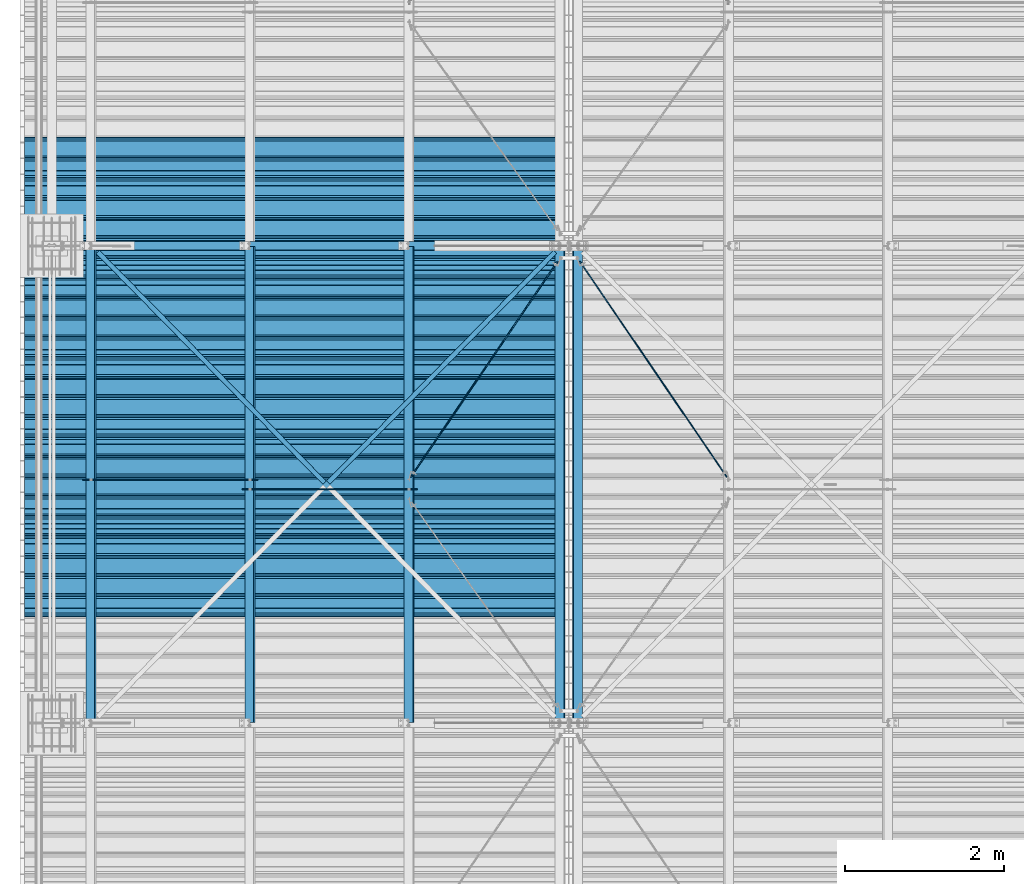
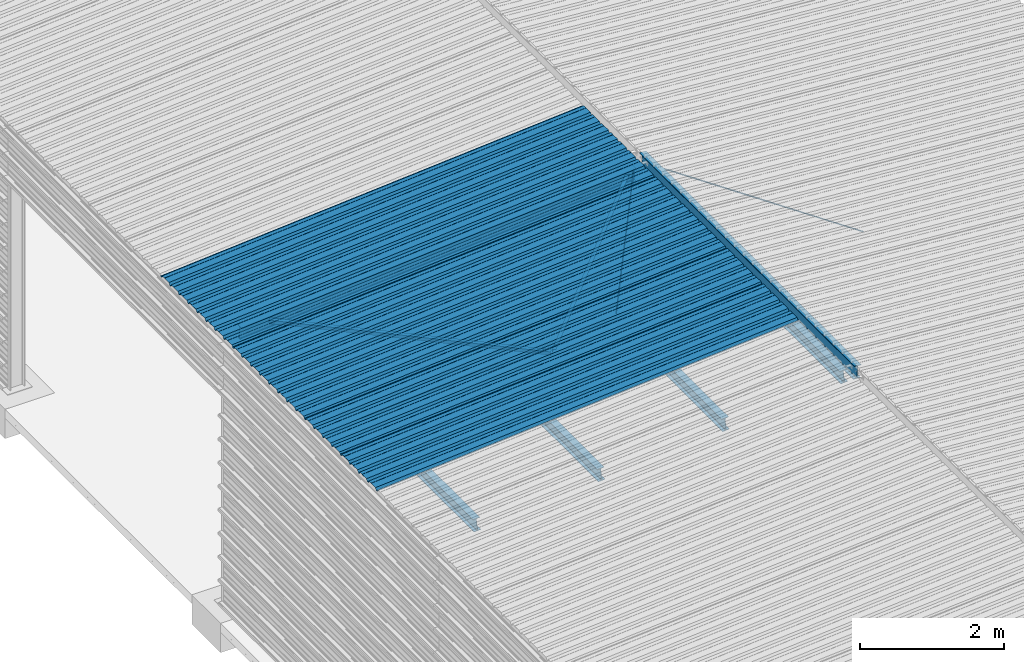
# One storey, part 11 of 70: 18 beams, 18 elements without a shape of their own.
"""IFC2X3 building model written with IfcOpenShell, lengths in millimetres."""

import ifcopenshell
import ifcopenshell.guid

model = None  # the IFC model being written
_history = None  # IfcOwnerHistory: only IFC2X3 demands one
_inside = {}  # id of a spatial element -> (the spatial element, [elements in it])
_under = {}  # id of a project, library or spatial element -> (it, [spatial elements below it])
_declared = {}  # id of a project -> (the project, [libraries it declares])
_typed = {}  # id of a type object -> (the type object, [elements of that type])
_made_of = {}  # id of a material, layer set ... -> (it, [elements and type objects made of it])


def new_model(schema):
    """Start an empty IFC model of exactly this schema.

    Asked for "IFC4X3", IfcOpenShell would pick the latest addendum, in which some entities
    have other attributes; the version numbers below select the first issue.
    IFC2X3 requires an IfcOwnerHistory on every rooted entity: one is made here for all.
    """
    global model, _history
    if schema == "IFC4X3":
        model = ifcopenshell.file(schema_version=(4, 3, 0, 0))
    else:
        model = ifcopenshell.file(schema=schema)
    _inside.clear()
    _under.clear()
    _declared.clear()
    _typed.clear()
    _made_of.clear()
    _history = None
    if model.schema == "IFC2X3":
        org = make("IfcOrganization", Name="unknown")
        user = make(
            "IfcPersonAndOrganization",
            ThePerson=make("IfcPerson", FamilyName="unknown"),
            TheOrganization=org,
        )
        app = make(
            "IfcApplication",
            ApplicationDeveloper=org,
            Version="unknown",
            ApplicationFullName="unknown",
            ApplicationIdentifier="unknown",
        )
        _history = make(
            "IfcOwnerHistory",
            OwningUser=user,
            OwningApplication=app,
            ChangeAction="ADDED",
            CreationDate=0,
        )
    return model


def make(cls, **values):
    """One entity of the class cls with the attributes given. An attribute that is None is left unset."""
    return model.create_entity(
        cls, **{name: value for name, value in values.items() if value is not None}
    )


def rooted(cls, **values):
    """An entity with a GlobalId (a new one), such as an element, a storey or a relation."""
    return make(cls, GlobalId=ifcopenshell.guid.new(), OwnerHistory=_history, **values)


def si_unit(unit_type, name, prefix=None):
    """IfcSIUnit, for example si_unit("LENGTHUNIT", "METRE", prefix="MILLI")."""
    return make("IfcSIUnit", UnitType=unit_type, Prefix=prefix, Name=name)


def assignment(units):
    """IfcUnitAssignment: the units of a project."""
    return None if units is None else make("IfcUnitAssignment", Units=units)


def point(xyz):
    """IfcCartesianPoint."""
    return None if xyz is None else make("IfcCartesianPoint", Coordinates=xyz)


def direction(xyz):
    """IfcDirection."""
    return None if xyz is None else make("IfcDirection", DirectionRatios=xyz)


def frame(location, z_axis=None, x_axis=None):
    """IfcAxis2Placement3D, a coordinate frame: its origin and axes. An axis left out is left unset."""
    return make(
        "IfcAxis2Placement3D",
        Location=point(location),
        Axis=direction(z_axis),
        RefDirection=direction(x_axis),
    )


def frame_2d(location, x_axis=None):
    """IfcAxis2Placement2D, a coordinate frame in the plane: its origin and x axis."""
    return make(
        "IfcAxis2Placement2D", Location=point(location), RefDirection=direction(x_axis)
    )


def origin_with_axes():
    """The frame at (0, 0, 0) with the z axis (0, 0, 1) and the x axis (1, 0, 0) written out."""
    return frame((0.0, 0.0, 0.0), z_axis=(0.0, 0.0, 1.0), x_axis=(1.0, 0.0, 0.0))


def origin_2d_with_axis():
    """The frame at (0, 0) in the plane with the x axis (1, 0) written out."""
    return frame_2d((0.0, 0.0), x_axis=(1.0, 0.0))


def place(relative_to, where):
    """IfcLocalPlacement: puts the frame where relative to a parent placement (None: the world)."""
    return make(
        "IfcLocalPlacement", PlacementRelTo=relative_to, RelativePlacement=where
    )


def context(
    kind, dimensions, precision=None, world=None, true_north=None, identifier=None
):
    """IfcGeometricRepresentationContext, for example the 3D "Model" context."""
    return make(
        "IfcGeometricRepresentationContext",
        ContextIdentifier=identifier,
        ContextType=kind,
        CoordinateSpaceDimension=dimensions,
        Precision=precision,
        WorldCoordinateSystem=world,
        TrueNorth=true_north,
    )


def subcontext(parent, identifier, kind, view, scale=None):
    """IfcGeometricRepresentationSubContext, for example "Body" below "Model"."""
    return make(
        "IfcGeometricRepresentationSubContext",
        ContextIdentifier=identifier,
        ContextType=kind,
        ParentContext=parent,
        TargetScale=scale,
        TargetView=view,
    )


def project(units=None, contexts=None):
    """IfcProject with its units and contexts."""
    return rooted(
        "IfcProject",
        Name="project",
        RepresentationContexts=contexts,
        UnitsInContext=assignment(units),
    )


def spatial(cls, under=None, at=None, **own):
    """A site, building, storey or space (cls), placed at a placement, below another one or the project."""
    s = rooted(cls, ObjectPlacement=at, **own)
    if under is not None:
        _under.setdefault(under.id(), (under, []))[1].append(s)
    return s


def polyline(points):
    """IfcPolyline through the points."""
    return make("IfcPolyline", Points=[point(p) for p in points])


def profile(cls, at=None, kind="AREA", **sizes):
    """A parametric profile (cls). Its sizes go by their IFC names, for example OverallWidth=200.0."""
    return make(cls, ProfileType=kind, Position=at, **sizes)


def circle(**sizes):
    """IfcCircleProfileDef."""
    return profile("IfcCircleProfileDef", **sizes)


def i_section(**sizes):
    """IfcIShapeProfileDef."""
    return profile("IfcIShapeProfileDef", **sizes)


def l_section(**sizes):
    """IfcLShapeProfileDef."""
    return profile("IfcLShapeProfileDef", **sizes)


def outline(outer, holes=None, kind="AREA"):
    """IfcArbitraryClosedProfileDef: a profile drawn as a closed curve; with holes, ...WithVoids."""
    if holes is None:
        return make("IfcArbitraryClosedProfileDef", ProfileType=kind, OuterCurve=outer)
    return make(
        "IfcArbitraryProfileDefWithVoids",
        ProfileType=kind,
        OuterCurve=outer,
        InnerCurves=holes,
    )


def extrude(swept, where, along, depth):
    """IfcExtrudedAreaSolid: the profile swept, set in the frame where, extruded along a direction by depth."""
    return make(
        "IfcExtrudedAreaSolid",
        SweptArea=swept,
        Position=where,
        ExtrudedDirection=direction(along),
        Depth=depth,
    )


def clip(a, b, op="DIFFERENCE"):
    """IfcBooleanClippingResult: the solid a cut by the half space b."""
    return make(
        "IfcBooleanClippingResult", Operator=op, FirstOperand=a, SecondOperand=b
    )


def halfspace(plane, agree):
    """IfcHalfSpaceSolid: all space on one side of the plane z = 0 of the frame plane."""
    return make(
        "IfcHalfSpaceSolid",
        BaseSurface=make("IfcPlane", Position=plane),
        AgreementFlag=agree,
    )


def shape(context_of_items, identifier, shape_type, items):
    """IfcShapeRepresentation: the items that make up one representation, for example the "Body"."""
    return make(
        "IfcShapeRepresentation",
        ContextOfItems=context_of_items,
        RepresentationIdentifier=identifier,
        RepresentationType=shape_type,
        Items=items,
    )


def material(Name=None, Category=None):
    """IfcMaterial."""
    return make("IfcMaterial", Name=Name, Category=Category)


def made_of(thing, what):
    """Note that an element or type object is made of a material, layer set ...; save() writes the relation."""
    if what is not None:
        _made_of.setdefault(what.id(), (what, []))[1].append(thing)
    return thing


def type_object(cls, material=None, **own):
    """A type object (cls), such as IfcWallType, which elements share."""
    return made_of(rooted(cls, **own), material)


def element(
    cls,
    number,
    at=None,
    inside=None,
    cuts=None,
    type_object=None,
    material=None,
    context=None,
    identifier="Body",
    shape_type=None,
    held_by="IfcProductDefinitionShape",
    body=None,
    shapes=None,
    **own,
):
    """One element of the class cls, such as IfcWall. Its Tag is "e" and its number.

    at: its placement. inside: the storey or other place that contains it. cuts: it is an
    opening in that element (IfcRelVoidsElement). A single representation is given by context,
    identifier, shape_type and body (its items); several are given by shapes. held_by: the class
    of the entity that holds the representations. save() writes the other relations.
    """
    e = rooted(cls, Tag="e%d" % number, ObjectPlacement=at, **own)
    if body is not None:
        shapes = [shape(context, identifier, shape_type, body)]
    if shapes is not None:
        e.Representation = make(held_by, Representations=shapes)
    if inside is not None:
        _inside.setdefault(inside.id(), (inside, []))[1].append(e)
    if cuts is not None:
        rooted(
            "IfcRelVoidsElement", RelatingBuildingElement=cuts, RelatedOpeningElement=e
        )
    if type_object is not None:
        _typed.setdefault(type_object.id(), (type_object, []))[1].append(e)
    return made_of(e, material)


def aggregate(whole, parts):
    """IfcRelAggregates: a whole, such as a stair, and the parts it consists of."""
    return rooted("IfcRelAggregates", RelatingObject=whole, RelatedObjects=parts)


def save(model, path):
    """Write the relations noted so far, then the file.

    IfcRelAggregates (storeys below a building ...), IfcRelContainedInSpatialStructure (elements
    in a storey), IfcRelDefinesByType, IfcRelAssociatesMaterial and IfcRelDeclares: one each for
    every whole, place, type object, material and project.
    """
    for whole, parts in _under.values():
        aggregate(whole, parts)
    for where, things in _inside.values():
        rooted(
            "IfcRelContainedInSpatialStructure",
            RelatedElements=things,
            RelatingStructure=where,
        )
    for kind, things in _typed.values():
        rooted("IfcRelDefinesByType", RelatedObjects=things, RelatingType=kind)
    for what, things in _made_of.values():
        rooted("IfcRelAssociatesMaterial", RelatedObjects=things, RelatingMaterial=what)
    for by, libraries in _declared.values():
        rooted("IfcRelDeclares", RelatingContext=by, RelatedDefinitions=libraries)
    model.write(path)


model = new_model("IFC2X3")

# Units and contexts
model_context = context("Model", 3, precision=1e-05, world=origin_with_axes())
body_context = subcontext(model_context, "Body", "Model", "MODEL_VIEW")
ifc_project = project(units=[si_unit("LENGTHUNIT", "METRE", prefix="MILLI"), si_unit("AREAUNIT", "SQUARE_METRE"), si_unit("VOLUMEUNIT", "CUBIC_METRE"), si_unit("MASSUNIT", "GRAM", prefix="KILO"), si_unit("TIMEUNIT", "SECOND"), si_unit("PLANEANGLEUNIT", "RADIAN"), si_unit("SOLIDANGLEUNIT", "STERADIAN"), si_unit("THERMODYNAMICTEMPERATUREUNIT", "DEGREE_CELSIUS"), si_unit("LUMINOUSINTENSITYUNIT", "LUMEN")], contexts=[model_context])

# Site, building, storey
site_placement = place(None, origin_with_axes())
site = spatial("IfcSite", under=ifc_project, at=site_placement, CompositionType="ELEMENT")
building_placement = place(site_placement, origin_with_axes())
building = spatial("IfcBuilding", under=site, at=building_placement, Name="Undefined", CompositionType="ELEMENT")
storey_placement = place(building_placement, origin_with_axes())
storey = spatial("IfcBuildingStorey", under=building, at=storey_placement, Name="Undefined", CompositionType="ELEMENT", Elevation=0.0)

# Assembly, beam
assembly_1_placement = place(storey_placement, origin_with_axes())
assembly_1 = element("IfcElementAssembly", 1, at=assembly_1_placement, inside=storey, Name="Steel Assembly", AssemblyPlace="NOTDEFINED", PredefinedType="RIGID_FRAME")
ifc_material = material(Name="STEEL/S235JR")
beam_type_1 = type_object("IfcBeamType", Name="4.40", PredefinedType="NOTDEFINED")
beam_1_placement = place(assembly_1_placement, frame((6436.39248868039, 7850.0, 5336.31760454388), z_axis=(0.0766964990376782, 0.0, -0.997054485489817), x_axis=(-0.997054485489818, 0.0, -0.0766964990376602)))
beam_1 = element("IfcBeam", 2, at=beam_1_placement, type_object=beam_type_1, material=ifc_material, ObjectType="4.40", context=body_context, shape_type="SweptSolid", body=[
    extrude(outline(polyline([(509.415161132813, 19.5000000011705), (490.584838867188, 19.5000000011705), (468.084838867188, -20.4999999988113), (406.585784912109, -20.4999999988113), (404.585784912109, -18.4999999988122), (345.414215087891, -18.4999999988122), (343.414215087891, -20.4999999988113), (281.915161132813, -20.4999999988113), (259.415161132813, 19.5000000011705), (240.584854125977, 19.5000000011705), (218.084854125977, -20.4999999988113), (156.585784912109, -20.4999999988113), (154.585784912109, -18.4999999988122), (95.4142150878906, -18.4999999988122), (93.4142150878906, -20.4999999988113), (31.9151515960693, -20.4999999988113), (9.41515254974365, 19.5000000011705), (-9.41515254974365, 19.5000000011705), (-31.9151515960693, -20.4999999988113), (-93.4142150878906, -20.4999999988113), (-95.4142150878906, -18.4999999988122), (-154.585784912109, -18.4999999988122), (-156.585784912109, -20.4999999988113), (-218.084854125977, -20.4999999988113), (-240.584854125977, 19.5000000011705), (-259.415161132813, 19.5000000011705), (-281.915161132813, -20.4999999988113), (-343.414215087891, -20.4999999988113), (-345.414215087891, -18.4999999988122), (-404.585784912109, -18.4999999988122), (-406.585784912109, -20.4999999988113), (-468.084838867188, -20.4999999988113), (-490.584838867188, 19.5000000011705), (-509.415161132813, 19.5000000011705), (-516.482360839844, 6.9361057293263), (-517.353942871094, 7.42636680720625), (-510.0, 20.5000000011705), (-490.0, 20.5000000011705), (-467.5, -19.4999999988122), (-407.0, -19.4999999988122), (-405.0, -17.4999999988131), (-345.0, -17.4999999988131), (-343.0, -19.4999999988122), (-282.5, -19.4999999988122), (-260.0, 20.5000000011705), (-240.0, 20.5000000011705), (-217.5, -19.4999999988122), (-157.0, -19.4999999988122), (-155.0, -17.4999999988131), (-95.0, -17.4999999988131), (-93.0, -19.4999999988122), (-32.5, -19.4999999988122), (-10.0, 20.5000000011705), (10.0, 20.5000000011705), (32.5, -19.4999999988122), (93.0, -19.4999999988122), (95.0, -17.4999999988131), (155.0, -17.4999999988131), (157.0, -19.4999999988122), (217.5, -19.4999999988122), (240.0, 20.5000000011705), (260.0, 20.5000000011705), (282.5, -19.4999999988122), (343.0, -19.4999999988122), (345.0, -17.4999999988131), (405.0, -17.4999999988131), (407.0, -19.4999999988122), (467.5, -19.4999999988122), (490.0, 20.5000000011705), (510.0, 20.5000000011705), (517.353942871094, 7.42636680720625), (516.482360839844, 6.9361057293263), (509.415161132813, 19.5000000011705)])), frame((6799.99999999733, 2.8421709430404e-14, 0.0), z_axis=(-1.0, 0.0, 0.0), x_axis=(0.0, -1.0, 0.0)), (0.0, 0.0, 1.0), 6800.0),
])
aggregate(assembly_1, [beam_1])

assembly_2_placement = place(storey_placement, origin_with_axes())
assembly_2 = element("IfcElementAssembly", 3, at=assembly_2_placement, inside=storey, Name="Steel Assembly", AssemblyPlace="NOTDEFINED", PredefinedType="RIGID_FRAME")
beam_2_placement = place(assembly_2_placement, frame((6436.39248868039, 8850.0, 5336.31760454388), z_axis=(0.0766964990376782, 0.0, -0.997054485489817), x_axis=(-0.997054485489818, 0.0, -0.0766964990376602)))
beam_2 = element("IfcBeam", 4, at=beam_2_placement, type_object=beam_type_1, material=ifc_material, ObjectType="4.40", context=body_context, shape_type="SweptSolid", body=[
    extrude(outline(polyline([(509.415161132813, 19.5000000011705), (490.584838867188, 19.5000000011705), (468.084838867188, -20.4999999988113), (406.585784912109, -20.4999999988113), (404.585784912109, -18.4999999988122), (345.414215087891, -18.4999999988122), (343.414215087891, -20.4999999988113), (281.915161132813, -20.4999999988113), (259.415161132813, 19.5000000011705), (240.584854125977, 19.5000000011705), (218.084854125977, -20.4999999988113), (156.585784912109, -20.4999999988113), (154.585784912109, -18.4999999988122), (95.4142150878906, -18.4999999988122), (93.4142150878906, -20.4999999988113), (31.9151515960693, -20.4999999988113), (9.41515254974365, 19.5000000011705), (-9.41515254974365, 19.5000000011705), (-31.9151515960693, -20.4999999988113), (-93.4142150878906, -20.4999999988113), (-95.4142150878906, -18.4999999988122), (-154.585784912109, -18.4999999988122), (-156.585784912109, -20.4999999988113), (-218.084854125977, -20.4999999988113), (-240.584854125977, 19.5000000011705), (-259.415161132813, 19.5000000011705), (-281.915161132813, -20.4999999988113), (-343.414215087891, -20.4999999988113), (-345.414215087891, -18.4999999988122), (-404.585784912109, -18.4999999988122), (-406.585784912109, -20.4999999988113), (-468.084838867188, -20.4999999988113), (-490.584838867188, 19.5000000011705), (-509.415161132813, 19.5000000011705), (-516.482360839844, 6.9361057293263), (-517.353942871094, 7.42636680720625), (-510.0, 20.5000000011705), (-490.0, 20.5000000011705), (-467.5, -19.4999999988122), (-407.0, -19.4999999988122), (-405.0, -17.4999999988131), (-345.0, -17.4999999988131), (-343.0, -19.4999999988122), (-282.5, -19.4999999988122), (-260.0, 20.5000000011705), (-240.0, 20.5000000011705), (-217.5, -19.4999999988122), (-157.0, -19.4999999988122), (-155.0, -17.4999999988131), (-95.0, -17.4999999988131), (-93.0, -19.4999999988122), (-32.5, -19.4999999988122), (-10.0, 20.5000000011705), (10.0, 20.5000000011705), (32.5, -19.4999999988122), (93.0, -19.4999999988122), (95.0, -17.4999999988131), (155.0, -17.4999999988131), (157.0, -19.4999999988122), (217.5, -19.4999999988122), (240.0, 20.5000000011705), (260.0, 20.5000000011705), (282.5, -19.4999999988122), (343.0, -19.4999999988122), (345.0, -17.4999999988131), (405.0, -17.4999999988131), (407.0, -19.4999999988122), (467.5, -19.4999999988122), (490.0, 20.5000000011705), (510.0, 20.5000000011705), (517.353942871094, 7.42636680720625), (516.482360839844, 6.9361057293263), (509.415161132813, 19.5000000011705)])), frame((6799.99999999733, 2.8421709430404e-14, 0.0), z_axis=(-1.0, 0.0, 0.0), x_axis=(0.0, -1.0, 0.0)), (0.0, 0.0, 1.0), 6800.0),
])
aggregate(assembly_2, [beam_2])

assembly_3_placement = place(storey_placement, origin_with_axes())
assembly_3 = element("IfcElementAssembly", 5, at=assembly_3_placement, inside=storey, Name="Steel Assembly", AssemblyPlace="NOTDEFINED", PredefinedType="RIGID_FRAME")
beam_3_placement = place(assembly_3_placement, frame((6436.39248868039, 9850.0, 5336.31760454388), z_axis=(0.0766964990376782, 0.0, -0.997054485489817), x_axis=(-0.997054485489818, 0.0, -0.0766964990376602)))
beam_3 = element("IfcBeam", 6, at=beam_3_placement, type_object=beam_type_1, material=ifc_material, ObjectType="4.40", context=body_context, shape_type="SweptSolid", body=[
    extrude(outline(polyline([(509.415161132813, 19.5000000011705), (490.584838867188, 19.5000000011705), (468.084838867188, -20.4999999988113), (406.585784912109, -20.4999999988113), (404.585784912109, -18.4999999988122), (345.414215087891, -18.4999999988122), (343.414215087891, -20.4999999988113), (281.915161132813, -20.4999999988113), (259.415161132813, 19.5000000011705), (240.584854125977, 19.5000000011705), (218.084854125977, -20.4999999988113), (156.585784912109, -20.4999999988113), (154.585784912109, -18.4999999988122), (95.4142150878906, -18.4999999988122), (93.4142150878906, -20.4999999988113), (31.9151515960693, -20.4999999988113), (9.41515254974365, 19.5000000011705), (-9.41515254974365, 19.5000000011705), (-31.9151515960693, -20.4999999988113), (-93.4142150878906, -20.4999999988113), (-95.4142150878906, -18.4999999988122), (-154.585784912109, -18.4999999988122), (-156.585784912109, -20.4999999988113), (-218.084854125977, -20.4999999988113), (-240.584854125977, 19.5000000011705), (-259.415161132813, 19.5000000011705), (-281.915161132813, -20.4999999988113), (-343.414215087891, -20.4999999988113), (-345.414215087891, -18.4999999988122), (-404.585784912109, -18.4999999988122), (-406.585784912109, -20.4999999988113), (-468.084838867188, -20.4999999988113), (-490.584838867188, 19.5000000011705), (-509.415161132813, 19.5000000011705), (-516.482360839844, 6.9361057293263), (-517.353942871094, 7.42636680720625), (-510.0, 20.5000000011705), (-490.0, 20.5000000011705), (-467.5, -19.4999999988122), (-407.0, -19.4999999988122), (-405.0, -17.4999999988131), (-345.0, -17.4999999988131), (-343.0, -19.4999999988122), (-282.5, -19.4999999988122), (-260.0, 20.5000000011705), (-240.0, 20.5000000011705), (-217.5, -19.4999999988122), (-157.0, -19.4999999988122), (-155.0, -17.4999999988131), (-95.0, -17.4999999988131), (-93.0, -19.4999999988122), (-32.5, -19.4999999988122), (-10.0, 20.5000000011705), (10.0, 20.5000000011705), (32.5, -19.4999999988122), (93.0, -19.4999999988122), (95.0, -17.4999999988131), (155.0, -17.4999999988131), (157.0, -19.4999999988122), (217.5, -19.4999999988122), (240.0, 20.5000000011705), (260.0, 20.5000000011705), (282.5, -19.4999999988122), (343.0, -19.4999999988122), (345.0, -17.4999999988131), (405.0, -17.4999999988131), (407.0, -19.4999999988122), (467.5, -19.4999999988122), (490.0, 20.5000000011705), (510.0, 20.5000000011705), (517.353942871094, 7.42636680720625), (516.482360839844, 6.9361057293263), (509.415161132813, 19.5000000011705)])), frame((6799.99999999733, 2.8421709430404e-14, 0.0), z_axis=(-1.0, 0.0, 0.0), x_axis=(0.0, -1.0, 0.0)), (0.0, 0.0, 1.0), 6800.0),
])
aggregate(assembly_3, [beam_3])

assembly_4_placement = place(storey_placement, origin_with_axes())
assembly_4 = element("IfcElementAssembly", 7, at=assembly_4_placement, inside=storey, Name="Steel Assembly", AssemblyPlace="NOTDEFINED", PredefinedType="RIGID_FRAME")
beam_4_placement = place(assembly_4_placement, frame((6436.39248868039, 10850.0, 5336.31760454388), z_axis=(0.0766964990376782, 0.0, -0.997054485489817), x_axis=(-0.997054485489818, 0.0, -0.0766964990376602)))
beam_4 = element("IfcBeam", 8, at=beam_4_placement, type_object=beam_type_1, material=ifc_material, ObjectType="4.40", context=body_context, shape_type="SweptSolid", body=[
    extrude(outline(polyline([(509.415161132813, 19.5000000011705), (490.584838867188, 19.5000000011705), (468.084838867188, -20.4999999988113), (406.585784912109, -20.4999999988113), (404.585784912109, -18.4999999988122), (345.414215087891, -18.4999999988122), (343.414215087891, -20.4999999988113), (281.915161132813, -20.4999999988113), (259.415161132813, 19.5000000011705), (240.584854125977, 19.5000000011705), (218.084854125977, -20.4999999988113), (156.585784912109, -20.4999999988113), (154.585784912109, -18.4999999988122), (95.4142150878906, -18.4999999988122), (93.4142150878906, -20.4999999988113), (31.9151515960693, -20.4999999988113), (9.41515254974365, 19.5000000011705), (-9.41515254974365, 19.5000000011705), (-31.9151515960693, -20.4999999988113), (-93.4142150878906, -20.4999999988113), (-95.4142150878906, -18.4999999988122), (-154.585784912109, -18.4999999988122), (-156.585784912109, -20.4999999988113), (-218.084854125977, -20.4999999988113), (-240.584854125977, 19.5000000011705), (-259.415161132813, 19.5000000011705), (-281.915161132813, -20.4999999988113), (-343.414215087891, -20.4999999988113), (-345.414215087891, -18.4999999988122), (-404.585784912109, -18.4999999988122), (-406.585784912109, -20.4999999988113), (-468.084838867188, -20.4999999988113), (-490.584838867188, 19.5000000011705), (-509.415161132813, 19.5000000011705), (-516.482360839844, 6.9361057293263), (-517.353942871094, 7.42636680720625), (-510.0, 20.5000000011705), (-490.0, 20.5000000011705), (-467.5, -19.4999999988122), (-407.0, -19.4999999988122), (-405.0, -17.4999999988131), (-345.0, -17.4999999988131), (-343.0, -19.4999999988122), (-282.5, -19.4999999988122), (-260.0, 20.5000000011705), (-240.0, 20.5000000011705), (-217.5, -19.4999999988122), (-157.0, -19.4999999988122), (-155.0, -17.4999999988131), (-95.0, -17.4999999988131), (-93.0, -19.4999999988122), (-32.5, -19.4999999988122), (-10.0, 20.5000000011705), (10.0, 20.5000000011705), (32.5, -19.4999999988122), (93.0, -19.4999999988122), (95.0, -17.4999999988131), (155.0, -17.4999999988131), (157.0, -19.4999999988122), (217.5, -19.4999999988122), (240.0, 20.5000000011705), (260.0, 20.5000000011705), (282.5, -19.4999999988122), (343.0, -19.4999999988122), (345.0, -17.4999999988131), (405.0, -17.4999999988131), (407.0, -19.4999999988122), (467.5, -19.4999999988122), (490.0, 20.5000000011705), (510.0, 20.5000000011705), (517.353942871094, 7.42636680720625), (516.482360839844, 6.9361057293263), (509.415161132813, 19.5000000011705)])), frame((6799.99999999733, 2.8421709430404e-14, 0.0), z_axis=(-1.0, 0.0, 0.0), x_axis=(0.0, -1.0, 0.0)), (0.0, 0.0, 1.0), 6800.0),
])
aggregate(assembly_4, [beam_4])

assembly_5_placement = place(storey_placement, origin_with_axes())
assembly_5 = element("IfcElementAssembly", 9, at=assembly_5_placement, inside=storey, Name="Steel Assembly", AssemblyPlace="NOTDEFINED", PredefinedType="RIGID_FRAME")
beam_5_placement = place(assembly_5_placement, frame((6436.39248868039, 11850.0, 5336.31760454388), z_axis=(0.0766964990376782, 0.0, -0.997054485489817), x_axis=(-0.997054485489818, 0.0, -0.0766964990376602)))
beam_5 = element("IfcBeam", 10, at=beam_5_placement, type_object=beam_type_1, material=ifc_material, ObjectType="4.40", context=body_context, shape_type="SweptSolid", body=[
    extrude(outline(polyline([(509.415161132813, 19.5000000011705), (490.584838867188, 19.5000000011705), (468.084838867188, -20.4999999988113), (406.585784912109, -20.4999999988113), (404.585784912109, -18.4999999988122), (345.414215087891, -18.4999999988122), (343.414215087891, -20.4999999988113), (281.915161132813, -20.4999999988113), (259.415161132813, 19.5000000011705), (240.584854125977, 19.5000000011705), (218.084854125977, -20.4999999988113), (156.585784912109, -20.4999999988113), (154.585784912109, -18.4999999988122), (95.4142150878906, -18.4999999988122), (93.4142150878906, -20.4999999988113), (31.9151515960693, -20.4999999988113), (9.41515254974365, 19.5000000011705), (-9.41515254974365, 19.5000000011705), (-31.9151515960693, -20.4999999988113), (-93.4142150878906, -20.4999999988113), (-95.4142150878906, -18.4999999988122), (-154.585784912109, -18.4999999988122), (-156.585784912109, -20.4999999988113), (-218.084854125977, -20.4999999988113), (-240.584854125977, 19.5000000011705), (-259.415161132813, 19.5000000011705), (-281.915161132813, -20.4999999988113), (-343.414215087891, -20.4999999988113), (-345.414215087891, -18.4999999988122), (-404.585784912109, -18.4999999988122), (-406.585784912109, -20.4999999988113), (-468.084838867188, -20.4999999988113), (-490.584838867188, 19.5000000011705), (-509.415161132813, 19.5000000011705), (-516.482360839844, 6.9361057293263), (-517.353942871094, 7.42636680720625), (-510.0, 20.5000000011705), (-490.0, 20.5000000011705), (-467.5, -19.4999999988122), (-407.0, -19.4999999988122), (-405.0, -17.4999999988131), (-345.0, -17.4999999988131), (-343.0, -19.4999999988122), (-282.5, -19.4999999988122), (-260.0, 20.5000000011705), (-240.0, 20.5000000011705), (-217.5, -19.4999999988122), (-157.0, -19.4999999988122), (-155.0, -17.4999999988131), (-95.0, -17.4999999988131), (-93.0, -19.4999999988122), (-32.5, -19.4999999988122), (-10.0, 20.5000000011705), (10.0, 20.5000000011705), (32.5, -19.4999999988122), (93.0, -19.4999999988122), (95.0, -17.4999999988131), (155.0, -17.4999999988131), (157.0, -19.4999999988122), (217.5, -19.4999999988122), (240.0, 20.5000000011705), (260.0, 20.5000000011705), (282.5, -19.4999999988122), (343.0, -19.4999999988122), (345.0, -17.4999999988131), (405.0, -17.4999999988131), (407.0, -19.4999999988122), (467.5, -19.4999999988122), (490.0, 20.5000000011705), (510.0, 20.5000000011705), (517.353942871094, 7.42636680720625), (516.482360839844, 6.9361057293263), (509.415161132813, 19.5000000011705)])), frame((6799.99999999733, 2.8421709430404e-14, 0.0), z_axis=(-1.0, 0.0, 0.0), x_axis=(0.0, -1.0, 0.0)), (0.0, 0.0, 1.0), 6800.0),
])
aggregate(assembly_5, [beam_5])

assembly_6_placement = place(storey_placement, origin_with_axes())
assembly_6 = element("IfcElementAssembly", 11, at=assembly_6_placement, inside=storey, Name="Steel Assembly", AssemblyPlace="NOTDEFINED", PredefinedType="RIGID_FRAME")
beam_6_placement = place(assembly_6_placement, frame((6436.39248868039, 12850.0, 5336.31760454388), z_axis=(0.0766964990376782, 0.0, -0.997054485489817), x_axis=(-0.997054485489818, 0.0, -0.0766964990376602)))
beam_6 = element("IfcBeam", 12, at=beam_6_placement, type_object=beam_type_1, material=ifc_material, ObjectType="4.40", context=body_context, shape_type="SweptSolid", body=[
    extrude(outline(polyline([(509.415161132813, 19.5000000011705), (490.584838867188, 19.5000000011705), (468.084838867188, -20.4999999988113), (406.585784912109, -20.4999999988113), (404.585784912109, -18.4999999988122), (345.414215087891, -18.4999999988122), (343.414215087891, -20.4999999988113), (281.915161132813, -20.4999999988113), (259.415161132813, 19.5000000011705), (240.584854125977, 19.5000000011705), (218.084854125977, -20.4999999988113), (156.585784912109, -20.4999999988113), (154.585784912109, -18.4999999988122), (95.4142150878906, -18.4999999988122), (93.4142150878906, -20.4999999988113), (31.9151515960693, -20.4999999988113), (9.41515254974365, 19.5000000011705), (-9.41515254974365, 19.5000000011705), (-31.9151515960693, -20.4999999988113), (-93.4142150878906, -20.4999999988113), (-95.4142150878906, -18.4999999988122), (-154.585784912109, -18.4999999988122), (-156.585784912109, -20.4999999988113), (-218.084854125977, -20.4999999988113), (-240.584854125977, 19.5000000011705), (-259.415161132813, 19.5000000011705), (-281.915161132813, -20.4999999988113), (-343.414215087891, -20.4999999988113), (-345.414215087891, -18.4999999988122), (-404.585784912109, -18.4999999988122), (-406.585784912109, -20.4999999988113), (-468.084838867188, -20.4999999988113), (-490.584838867188, 19.5000000011705), (-509.415161132813, 19.5000000011705), (-516.482360839844, 6.9361057293263), (-517.353942871094, 7.42636680720625), (-510.0, 20.5000000011705), (-490.0, 20.5000000011705), (-467.5, -19.4999999988122), (-407.0, -19.4999999988122), (-405.0, -17.4999999988131), (-345.0, -17.4999999988131), (-343.0, -19.4999999988122), (-282.5, -19.4999999988122), (-260.0, 20.5000000011705), (-240.0, 20.5000000011705), (-217.5, -19.4999999988122), (-157.0, -19.4999999988122), (-155.0, -17.4999999988131), (-95.0, -17.4999999988131), (-93.0, -19.4999999988122), (-32.5, -19.4999999988122), (-10.0, 20.5000000011705), (10.0, 20.5000000011705), (32.5, -19.4999999988122), (93.0, -19.4999999988122), (95.0, -17.4999999988131), (155.0, -17.4999999988131), (157.0, -19.4999999988122), (217.5, -19.4999999988122), (240.0, 20.5000000011705), (260.0, 20.5000000011705), (282.5, -19.4999999988122), (343.0, -19.4999999988122), (345.0, -17.4999999988131), (405.0, -17.4999999988131), (407.0, -19.4999999988122), (467.5, -19.4999999988122), (490.0, 20.5000000011705), (510.0, 20.5000000011705), (517.353942871094, 7.42636680720625), (516.482360839844, 6.9361057293263), (509.415161132813, 19.5000000011705)])), frame((6799.99999999733, 2.8421709430404e-14, 0.0), z_axis=(-1.0, 0.0, 0.0), x_axis=(0.0, -1.0, 0.0)), (0.0, 0.0, 1.0), 6800.0),
])
aggregate(assembly_6, [beam_6])

assembly_7_placement = place(storey_placement, origin_with_axes())
assembly_7 = element("IfcElementAssembly", 13, at=assembly_7_placement, inside=storey, Name="Steel Assembly", AssemblyPlace="NOTDEFINED", PredefinedType="RIGID_FRAME")
beam_type_2 = type_object("IfcBeamType", Name="D14", PredefinedType="NOTDEFINED")
beam_7_placement = place(assembly_7_placement, frame((6359.18519417644, 11802.4551827375, 5199.49305613506), z_axis=(0.0766964990376782, 0.0, -0.997054485489817), x_axis=(-0.5623502269338, -0.825766911902807, -0.0432577099949295)))
beam_7 = element("IfcBeam", 14, at=beam_7_placement, type_object=beam_type_2, material=ifc_material, Name="THREAD60MM", ObjectType="D14", context=body_context, shape_type="SweptSolid", body=[
    extrude(circle(Radius=7.0, at=origin_2d_with_axis()), frame((3280.87045158545, 4.90036175282065e-13, 0.0), z_axis=(-1.0, 0.0, 0.0), x_axis=(0.0, -1.0, 0.0)), (0.0, 0.0, 1.0), 3280.87),
])
aggregate(assembly_7, [beam_7])

assembly_8_placement = place(storey_placement, origin_with_axes())
assembly_8 = element("IfcElementAssembly", 15, at=assembly_8_placement, inside=storey, Name="Steel Assembly", AssemblyPlace="NOTDEFINED", PredefinedType="RIGID_FRAME")
beam_8_placement = place(assembly_8_placement, frame((6639.65995843849, 11804.1509849503, 5199.58189054979), z_axis=(-0.0766964990376782, 0.0, -0.997054485489817), x_axis=(0.562350226933823, -0.825766911902794, -0.0432577099948882)))
beam_8 = element("IfcBeam", 16, at=beam_8_placement, type_object=beam_type_2, material=ifc_material, Name="THREAD60MM", ObjectType="D14", context=body_context, shape_type="SweptSolid", body=[
    extrude(circle(Radius=7.0, at=origin_2d_with_axis()), frame((3282.92406040429, -1.63532676818866e-12, -9.32274563522658e-13), z_axis=(-1.0, 0.0, 0.0), x_axis=(0.0, -1.0, 0.0)), (0.0, 0.0, 1.0), 3282.92),
])
aggregate(assembly_8, [beam_8])

assembly_9_placement = place(storey_placement, origin_with_axes())
assembly_9 = element("IfcElementAssembly", 17, at=assembly_9_placement, inside=storey, Name="Steel Assembly", AssemblyPlace="NOTDEFINED", PredefinedType="RIGID_FRAME")
beam_9_placement = place(assembly_9_placement, frame((2591.26883365322, 9060.00000000009, 4909.65333500212), z_axis=(0.0766964990376782, 0.0, -0.997054485489817), x_axis=(-0.997054485489818, 0.0, -0.0766964990376602)))
beam_9 = element("IfcBeam", 18, at=beam_9_placement, type_object=beam_type_2, material=ifc_material, Name="THREAD60MM", ObjectType="D14", context=body_context, shape_type="SweptSolid", body=[
    extrude(circle(Radius=7.0, at=origin_2d_with_axis()), frame((2205.90843239298, 9.09494701772928e-13, -9.40107830921147e-13), z_axis=(-1.0, 0.0, 0.0), x_axis=(0.0, -1.0, 0.0)), (0.0, 0.0, 1.0), 2205.91),
])
aggregate(assembly_9, [beam_9])

assembly_10_placement = place(storey_placement, origin_with_axes())
assembly_10 = element("IfcElementAssembly", 19, at=assembly_10_placement, inside=storey, Name="Steel Assembly", AssemblyPlace="NOTDEFINED", PredefinedType="RIGID_FRAME")
beam_10_placement = place(assembly_10_placement, frame((4591.26883365324, 8940.00000000009, 5063.49948915789), z_axis=(0.0766964990376782, 0.0, -0.997054485489817), x_axis=(-0.997054485489818, 0.0, -0.0766964990376602)))
beam_10 = element("IfcBeam", 20, at=beam_10_placement, type_object=beam_type_2, material=ifc_material, Name="THREAD60MM", ObjectType="D14", context=body_context, shape_type="SweptSolid", body=[
    extrude(circle(Radius=7.0, at=origin_2d_with_axis()), frame((2205.90843239298, 9.09494701772928e-13, -9.40107830921147e-13), z_axis=(-1.0, 0.0, 0.0), x_axis=(0.0, -1.0, 0.0)), (0.0, 0.0, 1.0), 2205.91),
])
aggregate(assembly_10, [beam_10])

assembly_11_placement = place(storey_placement, origin_with_axes())
assembly_11 = element("IfcElementAssembly", 21, at=assembly_11_placement, inside=storey, Name="Steel Assembly", AssemblyPlace="NOTDEFINED", PredefinedType="RIGID_FRAME")
beam_type_3 = type_object("IfcBeamType", PredefinedType="NOTDEFINED")
beam_11_placement = place(assembly_11_placement, frame((6329.24443703513, 11923.9342773554, 5039.52551681506), z_axis=(0.0766964990376782, 0.0, -0.997054485489817), x_axis=(-0.700122412215615, -0.711988894219269, -0.0538555700165858)))
beam_11 = element("IfcBeam", 22, at=beam_11_placement, type_object=beam_type_3, material=ifc_material, Name="POUTRE", context=body_context, shape_type="Clipping", body=[
    clip(extrude(l_section(Depth=60.0, Width=60.0, Thickness=6.0, FilletRadius=8.0, EdgeRadius=4.0, at=origin_2d_with_axis()), frame((4136.90804481534, 1.75894358534081e-12, 0.0), z_axis=(-1.0, 0.0, 0.0), x_axis=(0.0, -1.0, 0.0)), (0.0, 0.0, 1.0), 4136.91), halfspace(frame((4072.73442480484, 30.0000000079531, -7.95353116700426e-09), z_axis=(-1.0, 0.0, 0.0), x_axis=(0.0, 0.0, 1.0)), True)),
])
aggregate(assembly_11, [beam_11])

assembly_12_placement = place(storey_placement, origin_with_axes())
assembly_12 = element("IfcElementAssembly", 23, at=assembly_12_placement, inside=storey, Name="Steel Assembly", AssemblyPlace="NOTDEFINED", PredefinedType="RIGID_FRAME")
beam_12_placement = place(assembly_12_placement, frame((578.84035998656, 11923.9342791634, 4597.18674290449), z_axis=(0.0766964990376782, 0.0, -0.997054485489817), x_axis=(0.700122412215615, -0.711988894219269, 0.0538555700165856)))
beam_12 = element("IfcBeam", 24, at=beam_12_placement, type_object=beam_type_3, material=ifc_material, Name="POUTRE", context=body_context, shape_type="Clipping", body=[
    clip(extrude(l_section(Depth=60.0, Width=60.0, Thickness=6.0, FilletRadius=8.0, EdgeRadius=4.0, at=origin_2d_with_axis()), frame((4136.90804481534, 1.75894358534081e-12, 0.0), z_axis=(-1.0, 0.0, 0.0), x_axis=(0.0, -1.0, 0.0)), (0.0, 0.0, 1.0), 4136.91), halfspace(frame((4072.73442480484, 30.0000000079531, -7.95353116700426e-09), z_axis=(-1.0, 0.0, 0.0), x_axis=(0.0, 0.0, 1.0)), True)),
])
aggregate(assembly_12, [beam_12])

assembly_13_placement = place(storey_placement, origin_with_axes())
assembly_13 = element("IfcElementAssembly", 25, at=assembly_13_placement, inside=storey, Name="Steel Assembly", AssemblyPlace="NOTDEFINED", PredefinedType="RIGID_FRAME")
beam_type_4 = type_object("IfcBeamType", Name="IPE220", PredefinedType="NOTDEFINED")
beam_13_placement = place(assembly_13_placement, frame((6608.43661485507, 6000.0, 5201.98368623401), z_axis=(0.0766964990376782, 0.0, 0.997054485489817), x_axis=(0.0, 1.0, 0.0)))
beam_13 = element("IfcBeam", 26, at=beam_13_placement, type_object=beam_type_4, material=ifc_material, ObjectType="IPE220", context=body_context, shape_type="Clipping", body=[
    clip(clip(extrude(i_section(OverallWidth=110.0, OverallDepth=220.0, WebThickness=5.900000095, FlangeThickness=9.199999809, FilletRadius=12.0, at=origin_2d_with_axis()), frame((5995.0, 1.81898940354586e-12, 0.0), z_axis=(-1.0, 0.0, 0.0), x_axis=(0.0, -1.0, 0.0)), (0.0, 0.0, 1.0), 5990.0), halfspace(frame((5995.0, 1.81898940354586e-12, 0.0), z_axis=(1.0, 0.0, 0.0), x_axis=(0.0, -1.0, 0.0)), False)), halfspace(frame((4.99999999999636, 7.09405867382884e-11, -1.79170456249267e-10), z_axis=(1.0, 0.0, 0.0), x_axis=(0.0, -1.0, 0.0)), True)),
])
aggregate(assembly_13, [beam_13])

assembly_14_placement = place(storey_placement, origin_with_axes())
assembly_14 = element("IfcElementAssembly", 27, at=assembly_14_placement, inside=storey, Name="Steel Assembly", AssemblyPlace="NOTDEFINED", PredefinedType="RIGID_FRAME")
beam_14_placement = place(assembly_14_placement, frame((6391.5633851416, 12000.0, 5201.98368622861), z_axis=(-0.0766964990376602, 0.0, 0.997054485489818), x_axis=(0.0, -1.0, 0.0)))
beam_14 = element("IfcBeam", 28, at=beam_14_placement, type_object=beam_type_4, material=ifc_material, ObjectType="IPE220", context=body_context, shape_type="Clipping", body=[
    clip(clip(extrude(i_section(OverallWidth=110.0, OverallDepth=220.0, WebThickness=5.900000095, FlangeThickness=9.199999809, FilletRadius=12.0, at=origin_2d_with_axis()), frame((5995.0, 1.81898940354586e-12, 0.0), z_axis=(-1.0, 0.0, 0.0), x_axis=(0.0, -1.0, 0.0)), (0.0, 0.0, 1.0), 5990.0), halfspace(frame((5995.0, 1.81898940354586e-12, 0.0), z_axis=(1.0, 0.0, 0.0), x_axis=(0.0, -1.0, 0.0)), False)), halfspace(frame((4.99999999999636, 7.09405867382884e-11, -1.79170456249267e-10), z_axis=(1.0, 0.0, 0.0), x_axis=(0.0, -1.0, 0.0)), True)),
])
aggregate(assembly_14, [beam_14])

assembly_15_placement = place(storey_placement, origin_with_axes())
assembly_15 = element("IfcElementAssembly", 29, at=assembly_15_placement, inside=storey, Name="Steel Assembly", AssemblyPlace="NOTDEFINED", PredefinedType="RIGID_FRAME")
beam_15_placement = place(assembly_15_placement, frame((4491.56338513012, 12000.0, 5055.82983992494), z_axis=(-0.0766964990376602, 0.0, 0.997054485489818), x_axis=(0.0, -1.0, 0.0)))
beam_15 = element("IfcBeam", 30, at=beam_15_placement, type_object=beam_type_4, material=ifc_material, ObjectType="IPE220", context=body_context, shape_type="Clipping", body=[
    clip(clip(extrude(i_section(OverallWidth=110.0, OverallDepth=220.0, WebThickness=5.900000095, FlangeThickness=9.199999809, FilletRadius=12.0, at=origin_2d_with_axis()), frame((5995.0, 1.81898940354586e-12, 0.0), z_axis=(-1.0, 0.0, 0.0), x_axis=(0.0, -1.0, 0.0)), (0.0, 0.0, 1.0), 5990.0), halfspace(frame((5995.0, 1.81898940354586e-12, 0.0), z_axis=(1.0, 0.0, 0.0), x_axis=(0.0, -1.0, 0.0)), False)), halfspace(frame((4.99999999999636, 7.09405867382884e-11, -1.79170456249267e-10), z_axis=(1.0, 0.0, 0.0), x_axis=(0.0, -1.0, 0.0)), True)),
])
aggregate(assembly_15, [beam_15])

assembly_16_placement = place(storey_placement, origin_with_axes())
assembly_16 = element("IfcElementAssembly", 31, at=assembly_16_placement, inside=storey, Name="Steel Assembly", AssemblyPlace="NOTDEFINED", PredefinedType="RIGID_FRAME")
beam_16_placement = place(assembly_16_placement, frame((2491.56338511802, 12000.0, 4901.98368592109), z_axis=(-0.0766964990376602, 0.0, 0.997054485489818), x_axis=(0.0, -1.0, 0.0)))
beam_16 = element("IfcBeam", 32, at=beam_16_placement, type_object=beam_type_4, material=ifc_material, ObjectType="IPE220", context=body_context, shape_type="Clipping", body=[
    clip(clip(extrude(i_section(OverallWidth=110.0, OverallDepth=220.0, WebThickness=5.900000095, FlangeThickness=9.199999809, FilletRadius=12.0, at=origin_2d_with_axis()), frame((5995.0, 1.81898940354586e-12, 0.0), z_axis=(-1.0, 0.0, 0.0), x_axis=(0.0, -1.0, 0.0)), (0.0, 0.0, 1.0), 5990.0), halfspace(frame((5995.0, 1.81898940354586e-12, 0.0), z_axis=(1.0, 0.0, 0.0), x_axis=(0.0, -1.0, 0.0)), False)), halfspace(frame((4.99999999999636, 7.09405867382884e-11, -1.79170456249267e-10), z_axis=(1.0, 0.0, 0.0), x_axis=(0.0, -1.0, 0.0)), True)),
])
aggregate(assembly_16, [beam_16])

assembly_17_placement = place(storey_placement, origin_with_axes())
assembly_17 = element("IfcElementAssembly", 33, at=assembly_17_placement, inside=storey, Name="Steel Assembly", AssemblyPlace="NOTDEFINED", PredefinedType="RIGID_FRAME")
beam_17_placement = place(assembly_17_placement, frame((491.563385106105, 12000.0, 4748.13753191674), z_axis=(-0.0766964990376602, 0.0, 0.997054485489818), x_axis=(0.0, -1.0, 0.0)))
beam_17 = element("IfcBeam", 34, at=beam_17_placement, type_object=beam_type_4, material=ifc_material, ObjectType="IPE220", context=body_context, shape_type="Clipping", body=[
    clip(clip(extrude(i_section(OverallWidth=110.0, OverallDepth=220.0, WebThickness=5.900000095, FlangeThickness=9.199999809, FilletRadius=12.0, at=origin_2d_with_axis()), frame((5995.0, 1.81898940354586e-12, 0.0), z_axis=(-1.0, 0.0, 0.0), x_axis=(0.0, -1.0, 0.0)), (0.0, 0.0, 1.0), 5990.0), halfspace(frame((5995.0, 1.81898940354586e-12, 0.0), z_axis=(1.0, 0.0, 0.0), x_axis=(0.0, -1.0, 0.0)), False)), halfspace(frame((4.99999999999636, 7.09405867382884e-11, -1.79170456249267e-10), z_axis=(1.0, 0.0, 0.0), x_axis=(0.0, -1.0, 0.0)), True)),
])
aggregate(assembly_17, [beam_17])

assembly_18_placement = place(storey_placement, origin_with_axes())
assembly_18 = element("IfcElementAssembly", 35, at=assembly_18_placement, inside=storey, Name="Steel Assembly", AssemblyPlace="NOTDEFINED", PredefinedType="RIGID_FRAME")
beam_18_placement = place(assembly_18_placement, frame((8.43661487722628, 12000.0, 4490.32400659478), z_axis=(-0.0766964990376602, 0.0, 0.997054485489818), x_axis=(0.997054485489816, 0.0, 0.0766964990376847)))
beam_18 = element("IfcBeam", 36, at=beam_18_placement, type_object=beam_type_4, material=ifc_material, Name="POUTRE", ObjectType="IPE220", context=body_context, shape_type="Clipping", body=[
    clip(clip(extrude(i_section(OverallWidth=110.0, OverallDepth=220.0, WebThickness=5.900000095, FlangeThickness=9.199999809, FilletRadius=12.0, at=origin_2d_with_axis()), frame((6512.78885803273, 3.63797880709171e-12, 0.0), z_axis=(-1.0, 0.0, 0.0), x_axis=(0.0, -1.0, 0.0)), (0.0, 0.0, 1.0), 6402.94), halfspace(frame((6504.24658470657, 3.63797880709171e-12, 111.150446985645), z_axis=(-0.997054485489817, 0.0, 0.0766964990376713), x_axis=(0.0, -1.0, 0.0)), True)), halfspace(frame((118.475742245822, 3.63797880709171e-12, -110.000000009088), z_axis=(0.997054485489817, 0.0, -0.0766964990376783), x_axis=(0.0, -1.0, 0.0)), True)),
])
aggregate(assembly_18, [beam_18])

save(model, "model.ifc")
